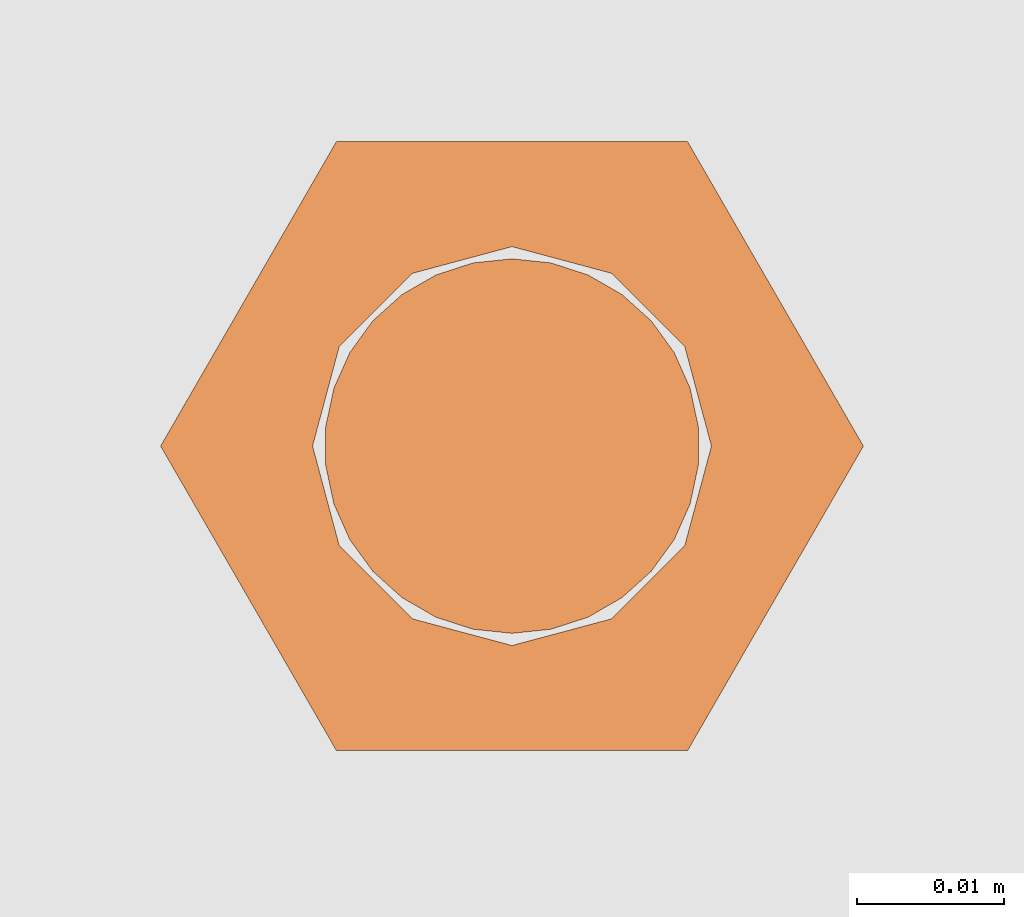
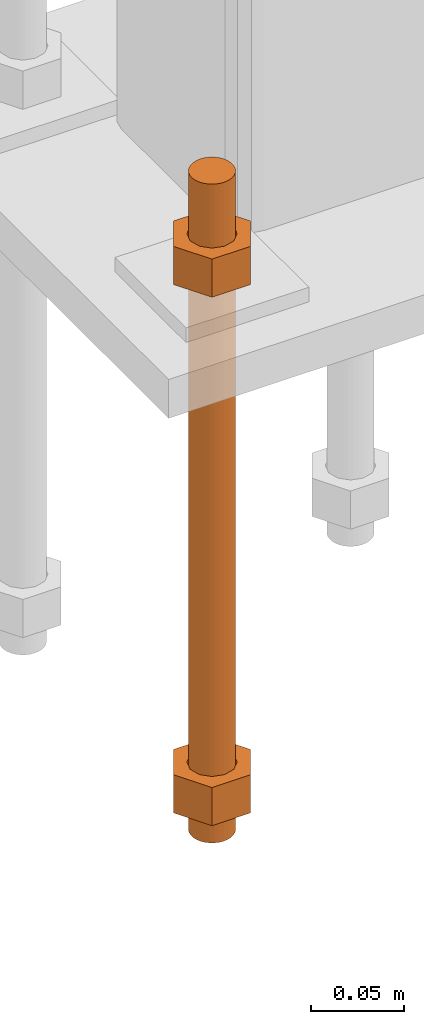
# One storey, part 22 of 89: 1 proxy.
"""IFC4 building model written with IfcOpenShell, lengths in feet."""

from ifc_helpers import new_model, entity, si_unit, converted_unit, derived_unit, direction, frame, origin, place, context, subcontext, project, spatial, faceted_brep, source, transform, mapped, material, constituent, constituent_set, type_object, type_shapes, element, save


model = new_model("IFC4")

# Units and contexts
model_context = context("Model", 3, precision=0.0001, world=origin(), true_north=direction((6.12303176911189e-17, 1.0)))
body_context = subcontext(model_context, "Body", "Model", "MODEL_VIEW")
ifc_project = project(units=[converted_unit("LENGTHUNIT", "FOOT", entity("IfcRatioMeasure", 0.3048), si_unit("LENGTHUNIT", "METRE"), dimensions=[1, 0, 0, 0, 0, 0, 0]), converted_unit("AREAUNIT", "SQUARE FOOT", entity("IfcRatioMeasure", 0.09290304), si_unit("AREAUNIT", "SQUARE_METRE"), dimensions=[2, 0, 0, 0, 0, 0, 0]), converted_unit("VOLUMEUNIT", "CUBIC FOOT", entity("IfcRatioMeasure", 0.028316846592), si_unit("VOLUMEUNIT", "CUBIC_METRE"), dimensions=[3, 0, 0, 0, 0, 0, 0]), si_unit("PLANEANGLEUNIT", "RADIAN"), si_unit("MASSUNIT", "GRAM", prefix="KILO"), derived_unit("MASSDENSITYUNIT", [(si_unit("MASSUNIT", "GRAM", prefix="KILO"), 1), (si_unit("LENGTHUNIT", "METRE"), -3)]), derived_unit("MOMENTOFINERTIAUNIT", [(si_unit("LENGTHUNIT", "METRE"), 4)]), si_unit("TIMEUNIT", "SECOND"), si_unit("FREQUENCYUNIT", "HERTZ"), si_unit("THERMODYNAMICTEMPERATUREUNIT", "DEGREE_CELSIUS"), derived_unit("THERMALTRANSMITTANCEUNIT", [(si_unit("MASSUNIT", "GRAM", prefix="KILO"), 1), (si_unit("THERMODYNAMICTEMPERATUREUNIT", "KELVIN"), -1), (si_unit("TIMEUNIT", "SECOND"), -3)]), derived_unit("VOLUMETRICFLOWRATEUNIT", [(si_unit("LENGTHUNIT", "METRE"), 3), (si_unit("TIMEUNIT", "SECOND"), -1)]), si_unit("ELECTRICCURRENTUNIT", "AMPERE"), si_unit("ELECTRICVOLTAGEUNIT", "VOLT"), si_unit("POWERUNIT", "WATT"), si_unit("FORCEUNIT", "NEWTON"), si_unit("ILLUMINANCEUNIT", "LUX"), si_unit("LUMINOUSFLUXUNIT", "LUMEN"), si_unit("LUMINOUSINTENSITYUNIT", "CANDELA"), derived_unit("USERDEFINED", [(si_unit("MASSUNIT", "GRAM", prefix="KILO"), -1), (si_unit("LENGTHUNIT", "METRE"), -2), (si_unit("TIMEUNIT", "SECOND"), 3), (si_unit("LUMINOUSFLUXUNIT", "LUMEN"), 1)]), derived_unit("LINEARVELOCITYUNIT", [(si_unit("LENGTHUNIT", "METRE"), 1), (si_unit("TIMEUNIT", "SECOND"), -1)]), si_unit("PRESSUREUNIT", "PASCAL"), derived_unit("USERDEFINED", [(si_unit("LENGTHUNIT", "METRE"), -2), (si_unit("MASSUNIT", "GRAM", prefix="KILO"), 1), (si_unit("TIMEUNIT", "SECOND"), -2)]), derived_unit("LINEARFORCEUNIT", [(si_unit("MASSUNIT", "GRAM", prefix="KILO"), 1), (si_unit("LENGTHUNIT", "METRE"), 1), (si_unit("TIMEUNIT", "SECOND"), -2), (si_unit("LENGTHUNIT", "METRE"), -1)]), derived_unit("PLANARFORCEUNIT", [(si_unit("MASSUNIT", "GRAM", prefix="KILO"), 1), (si_unit("LENGTHUNIT", "METRE"), 1), (si_unit("TIMEUNIT", "SECOND"), -2), (si_unit("LENGTHUNIT", "METRE"), -2)])], contexts=[model_context])

# Site, building, storey
site_placement = place(None, origin())
site = spatial("IfcSite", under=ifc_project, at=site_placement, CompositionType="ELEMENT")
building_placement = place(site_placement, frame((-472.238160486, -49.138065117, 0.0)))
building = spatial("IfcBuilding", under=site, at=building_placement, CompositionType="ELEMENT")
storey_placement = place(building_placement, origin())
storey = spatial("IfcBuildingStorey", under=building, at=storey_placement, Name="Level 1", CompositionType="ELEMENT", Elevation=0.0)

# Proxy
ifc_material_1 = material(Name="Color 7721", Category="Materials")
ifc_constituent_1 = constituent(ifc_material_1, Name="Color 7721", Category="Materials")
ifc_material_2 = material(Name="Color 7720", Category="Materials")
ifc_constituent_2 = constituent(ifc_material_2, Name="Color 7720", Category="Materials")
ifc_constituent_set = constituent_set(constituents=[ifc_constituent_1, ifc_constituent_2])
building_element_proxy_type = type_object("IfcBuildingElementProxyType", Name="rb2", PredefinedType="NOTDEFINED", material=ifc_material_1)
shared_shape = source(origin(), body_context, "Body", "Brep", [
    faceted_brep([(0.122545547339286, 0.0677083333333712, 0.0626666666666664), (0.156365697905557, 0.0677083333333712, 0.0626666666666664), (0.11727427342916, 0.135416666666742, 0.0626666666666664), (0.0390914244764247, 0.135416666666742, 0.0626666666666664), (0.0, 0.0677083333333712, 0.0626666666666664), (0.0338201505662994, 0.0677083333333712, 0.0626666666666664), (0.0397636251696838, 0.089889682526632, 0.0626666666666664), (0.0560014997595601, 0.106127557116452, 0.0626666666666664), (0.0781828489527925, 0.112071031719893, 0.0626666666666664), (0.100364198146025, 0.106127557116452, 0.0626666666666664), (0.116602072735901, 0.089889682526632, 0.0626666666666664), (0.11727427342916, 0.0, 0.0626666666666664), (0.0390914244764247, 0.0, 0.0626666666666664), (0.0397636251696838, 0.0455269841401105, 0.0626666666666664), (0.0560014997595601, 0.029289109550291, 0.0626666666666664), (0.0781828489527925, 0.0233456349468497, 0.0626666666666664), (0.100364198146025, 0.029289109550291, 0.0626666666666664), (0.116602072735901, 0.0455269841401105, 0.0626666666666664), (0.0, 0.0677083333333712, 0.144697916666667), (0.0390914244764531, 0.135416666666742, 0.144697916666667), (0.11727427342916, 0.135416666666742, 0.144697916666667), (0.156365697905585, 0.0677083333333712, 0.144697916666667), (0.117274273429189, 0.0, 0.144697916666667), (0.0390914244764247, 0.0, 0.144697916666667), (0.122545547339286, 0.0677083333333712, 0.144697916666666), (0.0338201505662994, 0.0677083333333712, 0.144697916666666), (0.0397636251696838, 0.0455269841401105, 0.144697916666666), (0.0560014997595601, 0.029289109550291, 0.144697916666666), (0.0781828489527925, 0.0233456349468497, 0.144697916666666), (0.100364198146025, 0.029289109550291, 0.144697916666666), (0.116602072735901, 0.0455269841401105, 0.144697916666666), (0.0397636251696838, 0.089889682526632, 0.144697916666666), (0.0560014997595601, 0.106127557116452, 0.144697916666666), (0.0781828489527925, 0.112071031719893, 0.144697916666666), (0.100364198146025, 0.106127557116452, 0.144697916666666), (0.116602072735901, 0.089889682526632, 0.144697916666666)], [[[0, 1, 2, 3, 4, 5, 6, 7, 8, 9, 10]], [[1, 11, 12, 4, 5, 13, 14, 15, 16, 17, 0]], [[4, 18, 19, 3]], [[3, 19, 20, 2]], [[2, 20, 21, 1]], [[1, 21, 22, 11]], [[11, 22, 23, 12]], [[12, 23, 18, 4]], [[24, 21, 22, 23, 18, 25, 26, 27, 28, 29, 30]], [[21, 20, 19, 18, 25, 31, 32, 33, 34, 35, 24]], [[25, 5, 6, 31]], [[31, 6, 7, 32]], [[32, 7, 8, 33]], [[33, 8, 9, 34]], [[34, 9, 10, 35]], [[35, 10, 0, 24]], [[24, 0, 17, 30]], [[30, 17, 16, 29]], [[29, 16, 15, 28]], [[28, 15, 14, 27]], [[27, 14, 13, 26]], [[26, 13, 5, 25]]]),
    faceted_brep([(0.0338201505662994, 0.0677083333333712, 1.28108333333333), (0.0, 0.0677083333333712, 1.28108333333333), (0.0390914244764247, 0.135416666666742, 1.28108333333333), (0.11727427342916, 0.135416666666742, 1.28108333333333), (0.156365697905557, 0.0677083333333712, 1.28108333333333), (0.122545547339286, 0.0677083333333712, 1.28108333333333), (0.116602072735901, 0.089889682526632, 1.28108333333333), (0.100364198146025, 0.106127557116452, 1.28108333333333), (0.0781828489527925, 0.112071031719893, 1.28108333333333), (0.0560014997595601, 0.106127557116452, 1.28108333333333), (0.0397636251696838, 0.089889682526632, 1.28108333333333), (0.0390914244764247, 0.0, 1.28108333333333), (0.11727427342916, 0.0, 1.28108333333333), (0.116602072735901, 0.0455269841401105, 1.28108333333333), (0.100364198146025, 0.029289109550291, 1.28108333333333), (0.0781828489527925, 0.0233456349468497, 1.28108333333333), (0.0560014997595601, 0.029289109550291, 1.28108333333333), (0.0397636251696838, 0.0455269841401105, 1.28108333333333), (0.156365697905528, 0.0677083333333712, 1.19905208333333), (0.117274273429132, 0.135416666666742, 1.19905208333333), (0.0390914244764247, 0.135416666666742, 1.19905208333333), (0.0, 0.0677083333333712, 1.19905208333333), (0.0390914244763962, 0.0, 1.19905208333333), (0.11727427342916, 0.0, 1.19905208333333), (0.0338201505662994, 0.0677083333333712, 1.19905208333333), (0.122545547339286, 0.0677083333333712, 1.19905208333333), (0.116602072735901, 0.0455269841401105, 1.19905208333333), (0.100364198146025, 0.029289109550291, 1.19905208333333), (0.0781828489527925, 0.0233456349468497, 1.19905208333333), (0.0560014997595601, 0.029289109550291, 1.19905208333333), (0.0397636251696838, 0.0455269841401105, 1.19905208333333), (0.116602072735901, 0.089889682526632, 1.19905208333333), (0.100364198146025, 0.106127557116452, 1.19905208333333), (0.0781828489527925, 0.112071031719893, 1.19905208333333), (0.0560014997595601, 0.106127557116452, 1.19905208333333), (0.0397636251696838, 0.089889682526632, 1.19905208333333)], [[[0, 1, 2, 3, 4, 5, 6, 7, 8, 9, 10]], [[1, 11, 12, 4, 5, 13, 14, 15, 16, 17, 0]], [[4, 18, 19, 3]], [[3, 19, 20, 2]], [[2, 20, 21, 1]], [[1, 21, 22, 11]], [[11, 22, 23, 12]], [[12, 23, 18, 4]], [[24, 21, 22, 23, 18, 25, 26, 27, 28, 29, 30]], [[21, 20, 19, 18, 25, 31, 32, 33, 34, 35, 24]], [[25, 5, 6, 31]], [[31, 6, 7, 32]], [[32, 7, 8, 33]], [[33, 8, 9, 34]], [[34, 9, 10, 35]], [[35, 10, 0, 24]], [[24, 0, 17, 30]], [[30, 17, 16, 29]], [[29, 16, 15, 28]], [[28, 15, 14, 27]], [[27, 14, 13, 26]], [[26, 13, 5, 25]]]),
    faceted_brep([(0.0781828489527925, 0.0260416666667425, 0.0), (0.0695198618353743, 0.0269521833027966, 0.0), (0.0612354888246216, 0.029643939264929, 0.0), (0.0536917967739328, 0.0339992919010683, 0.0), (0.0472184812245757, 0.0398278914017283, 0.0), (0.0420984571284464, 0.046875, 0.0), (0.0385554941071575, 0.0548326252344395, 0.0), (0.0367444366457903, 0.0633529806972319, 0.0), (0.0367444366457903, 0.0720636859695105, 0.0), (0.0385554941071575, 0.0805840414323029, 0.0), (0.0420984571284464, 0.0885416666667425, 0.0), (0.0472184812245757, 0.0955887752650142, 0.0), (0.0536917967739328, 0.101417374765674, 0.0), (0.0612354888246216, 0.105772727401813, 0.0), (0.0695198618353743, 0.108464483363946, 0.0), (0.0781828489527925, 0.109375, 0.0), (0.0868458360702107, 0.108464483363946, 0.0), (0.0951302090809634, 0.105772727401813, 0.0), (0.102673901131652, 0.101417374765674, 0.0), (0.109147216681009, 0.0955887752650142, 0.0), (0.114267240777139, 0.0885416666667425, 0.0), (0.117810203798427, 0.0805840414323029, 0.0), (0.119621261259795, 0.0720636859695105, 0.0), (0.119621261259795, 0.0633529806972319, 0.0), (0.117810203798427, 0.0548326252344395, 0.0), (0.114267240777139, 0.046875, 0.0), (0.109147216681009, 0.0398278914017283, 0.0), (0.102673901131652, 0.0339992919010683, 0.0), (0.0951302090809634, 0.029643939264929, 0.0), (0.0868458360702107, 0.0269521833027966, 0.0), (0.0868458360702107, 0.0269521833027966, 1.41666666666667), (0.0951302090809634, 0.029643939264929, 1.41666666666667), (0.102673901131652, 0.0339992919010683, 1.41666666666667), (0.109147216681009, 0.0398278914017283, 1.41666666666667), (0.114267240777139, 0.046875, 1.41666666666667), (0.117810203798427, 0.0548326252344395, 1.41666666666667), (0.119621261259795, 0.0633529806972319, 1.41666666666667), (0.119621261259795, 0.0720636859695105, 1.41666666666667), (0.117810203798427, 0.0805840414323029, 1.41666666666667), (0.114267240777139, 0.0885416666667425, 1.41666666666667), (0.109147216681009, 0.0955887752650142, 1.41666666666667), (0.102673901131652, 0.101417374765674, 1.41666666666667), (0.0951302090809634, 0.105772727401813, 1.41666666666667), (0.0868458360702107, 0.108464483363946, 1.41666666666667), (0.0781828489527925, 0.109375, 1.41666666666667), (0.0695198618353743, 0.108464483363946, 1.41666666666667), (0.0612354888246216, 0.105772727401813, 1.41666666666667), (0.0536917967739328, 0.101417374765674, 1.41666666666667), (0.0472184812245757, 0.0955887752650142, 1.41666666666667), (0.0420984571284464, 0.0885416666667425, 1.41666666666667), (0.0385554941071575, 0.0805840414323029, 1.41666666666667), (0.0367444366457903, 0.0720636859695105, 1.41666666666667), (0.0367444366457903, 0.0633529806972319, 1.41666666666667), (0.0385554941071575, 0.0548326252344395, 1.41666666666667), (0.0420984571284464, 0.046875, 1.41666666666667), (0.0472184812245757, 0.0398278914017283, 1.41666666666667), (0.0536917967739328, 0.0339992919010683, 1.41666666666667), (0.0612354888246216, 0.029643939264929, 1.41666666666667), (0.0695198618353743, 0.0269521833027966, 1.41666666666667), (0.0781828489527925, 0.0260416666667425, 1.41666666666667), (0.0695198618353743, 0.0269521833027966, 0.25), (0.0781828489527925, 0.0260416666667425, 0.25), (0.0612354888246216, 0.029643939264929, 0.25), (0.0536917967739328, 0.0339992919010683, 0.25), (0.0472184812246326, 0.0398278914017283, 0.25), (0.0420984571284464, 0.046875, 0.25), (0.0385554941071575, 0.0548326252344395, 0.25), (0.0367444366457619, 0.0633529806972319, 0.25), (0.0367444366457903, 0.0720636859695105, 0.25), (0.0385554941071575, 0.0805840414323029, 0.25), (0.0420984571284464, 0.0885416666667425, 0.25), (0.0472184812245757, 0.0955887752650142, 0.25), (0.0536917967739612, 0.101417374765674, 0.25), (0.0612354888246216, 0.105772727401813, 0.25), (0.0695198618353743, 0.108464483363946, 0.25), (0.0781828489527925, 0.109375, 0.25), (0.0868458360702107, 0.108464483363946, 0.25), (0.0951302090809634, 0.105772727401813, 0.25), (0.102673901131652, 0.101417374765674, 0.25), (0.109147216681038, 0.0955887752650142, 0.25), (0.114267240777139, 0.0885416666667425, 0.25), (0.117810203798371, 0.0805840414323029, 0.25), (0.119621261259795, 0.0720636859695105, 0.25), (0.119621261259795, 0.0633529806972319, 0.25), (0.117810203798399, 0.0548326252344395, 0.25), (0.114267240777195, 0.046875, 0.25), (0.109147216681009, 0.0398278914017283, 0.25), (0.102673901131709, 0.0339992919010683, 0.25), (0.0951302090809634, 0.029643939264929, 0.25), (0.0868458360702107, 0.0269521833027966, 0.25), (0.0695198618353743, 0.0269521833027966, 0.916666666666667), (0.0781828489527925, 0.0260416666667425, 0.916666666666667), (0.0612354888246216, 0.029643939264929, 0.916666666666667), (0.0536917967739328, 0.0339992919010683, 0.916666666666667), (0.0472184812246326, 0.0398278914017283, 0.916666666666667), (0.0420984571284464, 0.046875, 0.916666666666667), (0.0385554941071575, 0.0548326252344395, 0.916666666666667), (0.0367444366457619, 0.0633529806972319, 0.916666666666667), (0.0367444366457903, 0.0720636859695105, 0.916666666666667), (0.0385554941071575, 0.0805840414323029, 0.916666666666667), (0.0420984571284464, 0.0885416666667425, 0.916666666666667), (0.0472184812245757, 0.0955887752650142, 0.916666666666667), (0.0536917967739612, 0.101417374765674, 0.916666666666667), (0.0612354888246216, 0.105772727401813, 0.916666666666667), (0.0695198618353743, 0.108464483363946, 0.916666666666667), (0.0781828489527925, 0.109375, 0.916666666666667), (0.0868458360702107, 0.108464483363946, 0.916666666666667), (0.0951302090809634, 0.105772727401813, 0.916666666666667), (0.102673901131652, 0.101417374765674, 0.916666666666667), (0.109147216681038, 0.0955887752650142, 0.916666666666667), (0.114267240777139, 0.0885416666667425, 0.916666666666667), (0.117810203798371, 0.0805840414323029, 0.916666666666667), (0.119621261259795, 0.0720636859695105, 0.916666666666667), (0.119621261259795, 0.0633529806972319, 0.916666666666667), (0.117810203798399, 0.0548326252344395, 0.916666666666667), (0.114267240777195, 0.046875, 0.916666666666667), (0.109147216681009, 0.0398278914017283, 0.916666666666667), (0.102673901131709, 0.0339992919010683, 0.916666666666667), (0.0951302090809634, 0.029643939264929, 0.916666666666667), (0.0868458360702107, 0.0269521833027966, 0.916666666666667)], [[[0, 1, 2, 3, 4, 5, 6, 7, 8, 9, 10, 11, 12, 13, 14, 15, 16, 17, 18, 19, 20, 21, 22, 23, 24, 25, 26, 27, 28, 29]], [[30, 31, 32, 33, 34, 35, 36, 37, 38, 39, 40, 41, 42, 43, 44, 45, 46, 47, 48, 49, 50, 51, 52, 53, 54, 55, 56, 57, 58, 59]], [[60, 1, 0, 61]], [[62, 2, 1, 60]], [[63, 3, 2, 62]], [[64, 4, 3, 63]], [[65, 5, 4, 64]], [[66, 6, 5, 65]], [[67, 7, 6, 66]], [[68, 8, 7, 67]], [[69, 9, 8, 68]], [[70, 10, 9, 69]], [[71, 11, 10, 70]], [[72, 12, 11, 71]], [[73, 13, 12, 72]], [[74, 14, 13, 73]], [[75, 15, 14, 74]], [[76, 16, 15, 75]], [[77, 17, 16, 76]], [[78, 18, 17, 77]], [[79, 19, 18, 78]], [[80, 20, 19, 79]], [[81, 21, 20, 80]], [[82, 22, 21, 81]], [[83, 23, 22, 82]], [[84, 24, 23, 83]], [[85, 25, 24, 84]], [[86, 26, 25, 85]], [[87, 27, 26, 86]], [[88, 28, 27, 87]], [[89, 29, 28, 88]], [[61, 0, 29, 89]], [[90, 60, 61, 91]], [[92, 62, 60, 90]], [[93, 63, 62, 92]], [[94, 64, 63, 93]], [[95, 65, 64, 94]], [[96, 66, 65, 95]], [[97, 67, 66, 96]], [[98, 68, 67, 97]], [[99, 69, 68, 98]], [[100, 70, 69, 99]], [[101, 71, 70, 100]], [[102, 72, 71, 101]], [[103, 73, 72, 102]], [[104, 74, 73, 103]], [[105, 75, 74, 104]], [[106, 76, 75, 105]], [[107, 77, 76, 106]], [[108, 78, 77, 107]], [[109, 79, 78, 108]], [[110, 80, 79, 109]], [[111, 81, 80, 110]], [[112, 82, 81, 111]], [[113, 83, 82, 112]], [[114, 84, 83, 113]], [[115, 85, 84, 114]], [[116, 86, 85, 115]], [[117, 87, 86, 116]], [[118, 88, 87, 117]], [[119, 89, 88, 118]], [[91, 61, 89, 119]], [[58, 90, 91, 59]], [[57, 92, 90, 58]], [[56, 93, 92, 57]], [[55, 94, 93, 56]], [[54, 95, 94, 55]], [[53, 96, 95, 54]], [[52, 97, 96, 53]], [[51, 98, 97, 52]], [[50, 99, 98, 51]], [[49, 100, 99, 50]], [[48, 101, 100, 49]], [[47, 102, 101, 48]], [[46, 103, 102, 47]], [[45, 104, 103, 46]], [[44, 105, 104, 45]], [[43, 106, 105, 44]], [[42, 107, 106, 43]], [[41, 108, 107, 42]], [[40, 109, 108, 41]], [[39, 110, 109, 40]], [[38, 111, 110, 39]], [[37, 112, 111, 38]], [[36, 113, 112, 37]], [[35, 114, 113, 36]], [[34, 115, 114, 35]], [[33, 116, 115, 34]], [[32, 117, 116, 33]], [[31, 118, 117, 32]], [[30, 119, 118, 31]], [[59, 91, 119, 30]]]),
])
type_shapes(building_element_proxy_type, [shared_shape])
proxy_placement = place(building_placement, frame((206.31765048438, 996.651041666667, -1.45833333333333)))
element("IfcBuildingElementProxy", 1, at=proxy_placement, inside=storey, type_object=building_element_proxy_type, material=ifc_constituent_set, Name="rb2 480:rb2 480", ObjectType="rb2 480:rb2 480", PredefinedType="NOTDEFINED", context=body_context, shape_type="MappedRepresentation", body=[
    mapped(shared_shape, transform((0.0, 0.0, 0.0), scale=1.0)),
])

save(model, "model.ifc")
